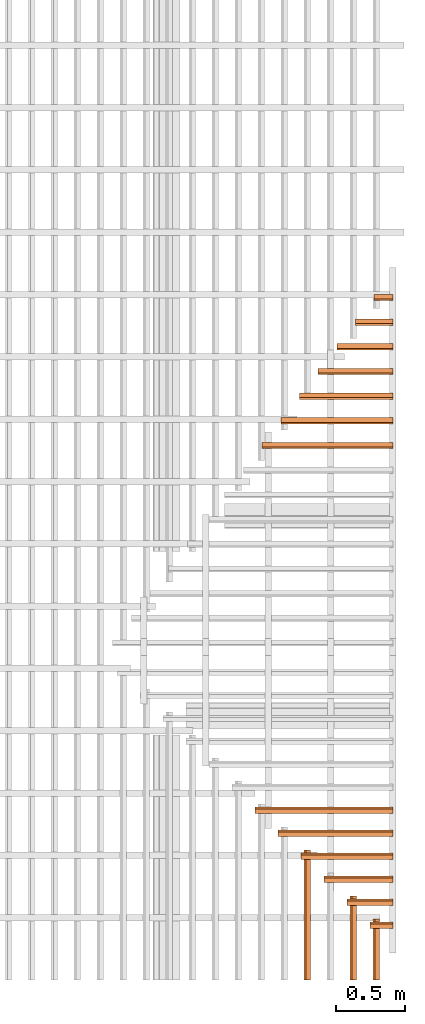
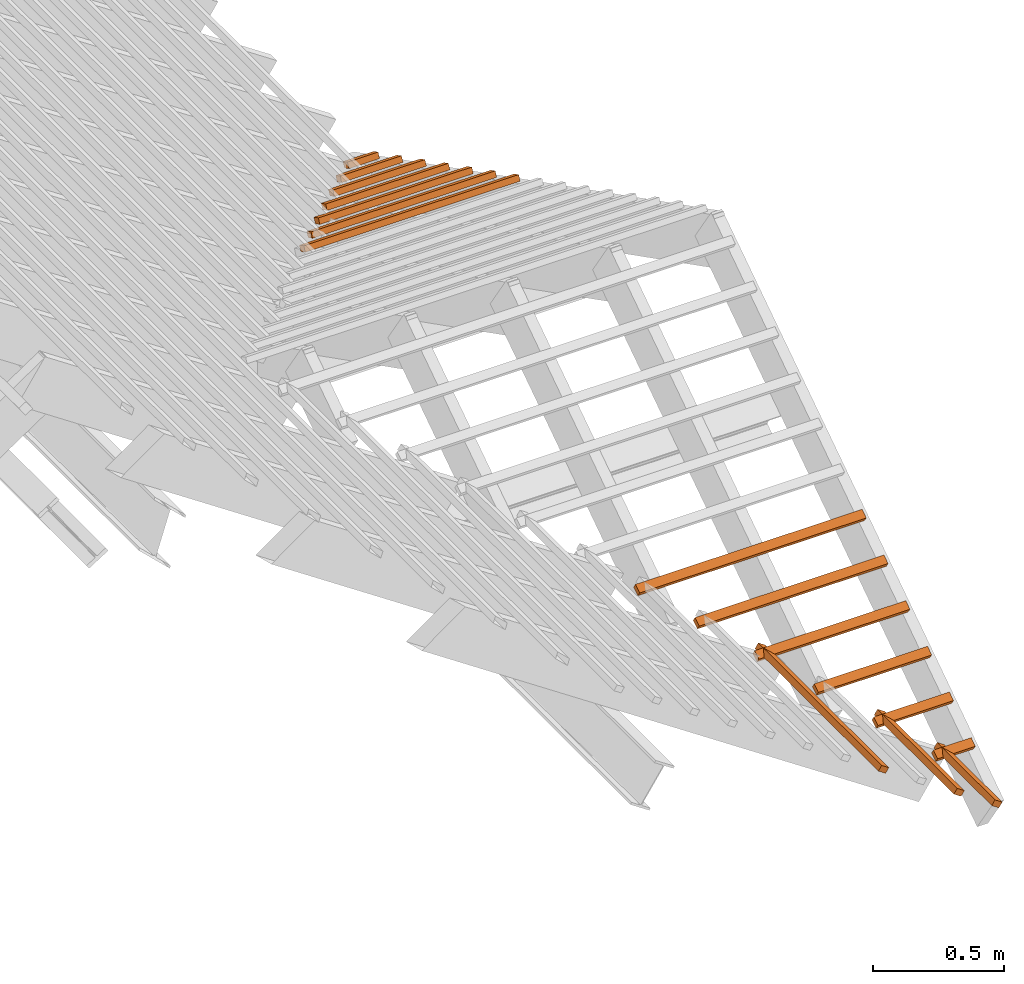
# One storey, part 3 of 3: 16 proxies, 4 elements without a shape of their own.
"""IFC4 building model written with IfcOpenShell, lengths in metres."""

from ifc_helpers import new_model, entity, si_unit, converted_unit, frame, frame_2d, origin_with_axes, origin_2d_with_axis, place, context, subcontext, project, library, spatial, rectangle, extrude, material, material_profile, profile_set, profile_usage, type_object, element, aggregate, save


model = new_model("IFC4")

# Units and contexts
model_context = context("Model", 3, precision=1e-05, world=origin_with_axes())
plan_context = context("Plan", 2, precision=1e-05, world=origin_2d_with_axis())
body_context = subcontext(model_context, "Body", "Model", "MODEL_VIEW")
ifc_project = project(units=[si_unit("LENGTHUNIT", "METRE"), converted_unit("PLANEANGLEUNIT", "degree", entity("IfcReal", 0.0174532925199433), si_unit("PLANEANGLEUNIT", "RADIAN"), dimensions=[0, 0, 0, 0, 0, 0, 0]), si_unit("AREAUNIT", "SQUARE_METRE"), si_unit("VOLUMEUNIT", "CUBIC_METRE")], contexts=[model_context, plan_context])
project_library_1 = library(declared=ifc_project)
project_library_2 = library(declared=ifc_project)
project_library_3 = library(declared=ifc_project)

# Site, building, storey
site_placement = place(None, frame((-0.0250487327575684, 0.0, 0.0), z_axis=(0.0, 0.0, 1.0), x_axis=(1.0, 0.0, 0.0)))
site = spatial("IfcSite", under=ifc_project, at=site_placement)
building_placement = place(site_placement, origin_with_axes())
building = spatial("IfcBuilding", under=site, at=building_placement, Name="Building")
storey_placement = place(building_placement, frame((0.0250487327575684, 0.0, 0.0), z_axis=(0.0, 0.0, 1.0), x_axis=(1.0, 0.0, 0.0)))
storey = spatial("IfcBuildingStorey", under=building, at=storey_placement, Name="Roof framing", CompositionType="ELEMENT", Elevation=0.0)

# Assemblies, proxies
assembly_1_placement = place(storey_placement, origin_with_axes())
assembly_1 = element("IfcElementAssembly", 1, at=assembly_1_placement, inside=storey, Name="battens")
assembly_2_placement = place(assembly_1_placement, frame((1.27500009536743, -6.61744490042422e-24, 2.40000009536743), z_axis=(0.557621447781006, -6.78052809385821e-09, 0.830095368602075), x_axis=(1.21597333116231e-08, 1.0, -6.86638795477696e-25)))
assembly_2 = element("IfcElementAssembly", 2, at=assembly_2_placement, Name="battens")
ifc_material = material(Name="Timber")
ifc_material_profile = material_profile(ifc_material, rectangle(XDim=0.038, YDim=0.026, at=frame_2d((0.0, 0.083), x_axis=(1.0, 0.0))))
ifc_profile_set = profile_set([ifc_material_profile])
ifc_profile_usage_1 = profile_usage(ifc_profile_set)
building_element_proxy_type = type_object("IfcBuildingElementProxyType", Name="batten", PredefinedType="NOTDEFINED", material=ifc_profile_set)
proxy_1_placement = place(assembly_2_placement, frame((0.441019033613307, 0.2, 0.0), z_axis=(-1.0, 0.0, 0.0), x_axis=(0.0, -1.0, 0.0)))
proxy_1 = element("IfcBuildingElementProxy", 3, at=proxy_1_placement, type_object=building_element_proxy_type, material=ifc_profile_usage_1, Name="batten", context=body_context, shape_type="SweptSolid", body=[
    extrude(rectangle(XDim=0.038, YDim=0.026, at=frame_2d((0.0, 0.083), x_axis=(1.0, 0.0))), origin_with_axes(), (0.0, 0.0, 1.0), 0.441019073436429),
])
ifc_profile_usage_2 = profile_usage(ifc_profile_set)
proxy_2_placement = place(assembly_2_placement, frame((0.607038093372632, 0.4, 0.0), z_axis=(-1.0, 0.0, 0.0), x_axis=(0.0, -1.0, 0.0)))
proxy_2 = element("IfcBuildingElementProxy", 4, at=proxy_2_placement, type_object=building_element_proxy_type, material=ifc_profile_usage_2, Name="batten", context=body_context, shape_type="SweptSolid", body=[
    extrude(rectangle(XDim=0.038, YDim=0.026, at=frame_2d((0.0, 0.083), x_axis=(1.0, 0.0))), origin_with_axes(), (0.0, 0.0, 1.0), 0.607038133195754),
])
ifc_profile_usage_3 = profile_usage(ifc_profile_set)
proxy_3_placement = place(assembly_2_placement, frame((0.939076212891283, 0.8, 0.0), z_axis=(-1.0, 1.18225013295358e-16, 0.0), x_axis=(-1.18225013295358e-16, -1.0, 0.0)))
proxy_3 = element("IfcBuildingElementProxy", 5, at=proxy_3_placement, type_object=building_element_proxy_type, material=ifc_profile_usage_3, Name="batten", context=body_context, shape_type="SweptSolid", body=[
    extrude(rectangle(XDim=0.038, YDim=0.026, at=frame_2d((0.0, 0.083), x_axis=(1.0, 0.0))), origin_with_axes(), (0.0, 0.0, 1.0), 0.939076252714405),
])
aggregate(assembly_2, [proxy_1, proxy_2, proxy_3])
assembly_3_placement = place(assembly_1_placement, frame((1.27500009536743, 5.06999969482422, 2.40000009536743), z_axis=(-1.8134071260532e-16, 0.453056810096847, 0.891481646936643), x_axis=(-1.0, -4.00260427751998e-16, -2.19767193434487e-32)))
assembly_3 = element("IfcElementAssembly", 6, at=assembly_3_placement, Name="battens")
ifc_profile_usage_4 = profile_usage(ifc_profile_set)
proxy_4_placement = place(assembly_3_placement, frame((0.134887384209834, 0.2, 0.0), z_axis=(-1.0, 6.17304736049078e-16, 0.0), x_axis=(-6.17304736049078e-16, -1.0, 0.0)))
proxy_4 = element("IfcBuildingElementProxy", 7, at=proxy_4_placement, type_object=building_element_proxy_type, material=ifc_profile_usage_4, Name="batten", context=body_context, shape_type="SweptSolid", body=[
    extrude(rectangle(XDim=0.038, YDim=0.026, at=frame_2d((0.0, 0.083), x_axis=(1.0, 0.0))), origin_with_axes(), (0.0, 0.0, 1.0), 0.134887555504299),
])
ifc_profile_usage_5 = profile_usage(ifc_profile_set)
proxy_5_placement = place(assembly_3_placement, frame((0.269774768419667, 0.4, 0.0), z_axis=(-1.0, 6.17304736049078e-16, 0.0), x_axis=(-6.17304736049078e-16, -1.0, 0.0)))
proxy_5 = element("IfcBuildingElementProxy", 8, at=proxy_5_placement, type_object=building_element_proxy_type, material=ifc_profile_usage_5, Name="batten", context=body_context, shape_type="SweptSolid", body=[
    extrude(rectangle(XDim=0.038, YDim=0.026, at=frame_2d((0.0, 0.083), x_axis=(1.0, 0.0))), origin_with_axes(), (0.0, 0.0, 1.0), 0.269775111008598),
])
ifc_profile_usage_6 = profile_usage(ifc_profile_set)
proxy_6_placement = place(assembly_3_placement, frame((0.404662152629501, 0.6, 0.0), z_axis=(-1.0, 5.48715320932513e-16, 0.0), x_axis=(-5.48715320932513e-16, -1.0, 0.0)))
proxy_6 = element("IfcBuildingElementProxy", 9, at=proxy_6_placement, type_object=building_element_proxy_type, material=ifc_profile_usage_6, Name="batten", context=body_context, shape_type="SweptSolid", body=[
    extrude(rectangle(XDim=0.038, YDim=0.026, at=frame_2d((0.0, 0.083), x_axis=(1.0, 0.0))), origin_with_axes(), (0.0, 0.0, 1.0), 0.404662666512898),
])
ifc_profile_usage_7 = profile_usage(ifc_profile_set)
proxy_7_placement = place(assembly_3_placement, frame((0.539549536839334, 0.8, 0.0), z_axis=(-1.0, -2.05768245349693e-16, 0.0), x_axis=(2.05768245349693e-16, -1.0, 0.0)))
proxy_7 = element("IfcBuildingElementProxy", 10, at=proxy_7_placement, type_object=building_element_proxy_type, material=ifc_profile_usage_7, Name="batten", context=body_context, shape_type="SweptSolid", body=[
    extrude(rectangle(XDim=0.038, YDim=0.026, at=frame_2d((0.0, 0.083), x_axis=(1.0, 0.0))), origin_with_axes(), (0.0, 0.0, 1.0), 0.539550222017197),
])
ifc_profile_usage_8 = profile_usage(ifc_profile_set)
proxy_8_placement = place(assembly_3_placement, frame((0.674436921049168, 1.0, 0.0), z_axis=(-1.0, 0.0, 0.0), x_axis=(0.0, -1.0, 0.0)))
proxy_8 = element("IfcBuildingElementProxy", 11, at=proxy_8_placement, type_object=building_element_proxy_type, material=ifc_profile_usage_8, Name="batten", context=body_context, shape_type="SweptSolid", body=[
    extrude(rectangle(XDim=0.038, YDim=0.026, at=frame_2d((0.0, 0.083), x_axis=(1.0, 0.0))), origin_with_axes(), (0.0, 0.0, 1.0), 0.674437777521496),
])
ifc_profile_usage_9 = profile_usage(ifc_profile_set)
proxy_9_placement = place(assembly_3_placement, frame((0.809324305259002, 1.2, 0.0), z_axis=(-1.0, 0.0, 0.0), x_axis=(0.0, -1.0, 0.0)))
proxy_9 = element("IfcBuildingElementProxy", 12, at=proxy_9_placement, type_object=building_element_proxy_type, material=ifc_profile_usage_9, Name="batten", context=body_context, shape_type="SweptSolid", body=[
    extrude(rectangle(XDim=0.038, YDim=0.026, at=frame_2d((0.0, 0.083), x_axis=(1.0, 0.0))), origin_with_axes(), (0.0, 0.0, 1.0), 0.809325333025795),
])
ifc_profile_usage_10 = profile_usage(ifc_profile_set)
proxy_10_placement = place(assembly_3_placement, frame((0.944211689468835, 1.4, 0.0), z_axis=(-1.0, 0.0, 0.0), x_axis=(0.0, -1.0, 0.0)))
proxy_10 = element("IfcBuildingElementProxy", 13, at=proxy_10_placement, type_object=building_element_proxy_type, material=ifc_profile_usage_10, Name="batten", context=body_context, shape_type="SweptSolid", body=[
    extrude(rectangle(XDim=0.038, YDim=0.026, at=frame_2d((0.0, 0.083), x_axis=(1.0, 0.0))), origin_with_axes(), (0.0, 0.0, 1.0), 0.944212888530094),
])
aggregate(assembly_3, [proxy_4, proxy_5, proxy_6, proxy_7, proxy_8, proxy_9, proxy_10])
assembly_4_placement = place(assembly_1_placement, frame((1.27500009536743, 0.274999976158142, 2.40000009536743), z_axis=(-5.93234342970621e-17, -0.55762137886684, 0.830095414895567), x_axis=(1.0, -1.0638658513706e-16, 0.0)))
assembly_4 = element("IfcElementAssembly", 14, at=assembly_4_placement, Name="battens")
aggregate(assembly_1, [assembly_2, assembly_3, assembly_4])
ifc_profile_usage_11 = profile_usage(ifc_profile_set)
proxy_11_placement = place(assembly_4_placement, frame((1.2649732309411e-06, 1.2, 0.0), z_axis=(-1.0, 4.45820806688113e-16, 0.0), x_axis=(-4.45820806688113e-16, -1.0, 0.0)))
proxy_11 = element("IfcBuildingElementProxy", 15, at=proxy_11_placement, type_object=building_element_proxy_type, material=ifc_profile_usage_11, Name="batten", context=body_context, shape_type="SweptSolid", body=[
    extrude(rectangle(XDim=0.038, YDim=0.026, at=frame_2d((0.0, 0.083), x_axis=(1.0, 0.0))), origin_with_axes(), (0.0, 0.0, 1.0), 0.996115935344262),
])
ifc_profile_usage_12 = profile_usage(ifc_profile_set)
proxy_12_placement = place(assembly_4_placement, frame((1.05414435891404e-06, 1.0, 0.0), z_axis=(-1.0, 0.0, 0.0), x_axis=(0.0, -1.0, 0.0)))
proxy_12 = element("IfcBuildingElementProxy", 16, at=proxy_12_placement, type_object=building_element_proxy_type, material=ifc_profile_usage_12, Name="batten", context=body_context, shape_type="SweptSolid", body=[
    extrude(rectangle(XDim=0.038, YDim=0.026, at=frame_2d((0.0, 0.083), x_axis=(1.0, 0.0))), origin_with_axes(), (0.0, 0.0, 1.0), 0.830096612786885),
])
ifc_profile_usage_13 = profile_usage(ifc_profile_set)
proxy_13_placement = place(assembly_4_placement, frame((8.43315487220053e-07, 0.8, 0.0), z_axis=(-1.0, 3.34365605016084e-16, 0.0), x_axis=(-3.34365605016084e-16, -1.0, 0.0)))
proxy_13 = element("IfcBuildingElementProxy", 17, at=proxy_13_placement, type_object=building_element_proxy_type, material=ifc_profile_usage_13, Name="batten", context=body_context, shape_type="SweptSolid", body=[
    extrude(rectangle(XDim=0.038, YDim=0.026, at=frame_2d((0.0, 0.083), x_axis=(1.0, 0.0))), origin_with_axes(), (0.0, 0.0, 1.0), 0.664077290229508),
])
ifc_profile_usage_14 = profile_usage(ifc_profile_set)
proxy_14_placement = place(assembly_4_placement, frame((6.32486615470551e-07, 0.6, 0.0), z_axis=(-1.0, 6.68731210032168e-16, 0.0), x_axis=(-6.68731210032168e-16, -1.0, 0.0)))
proxy_14 = element("IfcBuildingElementProxy", 18, at=proxy_14_placement, type_object=building_element_proxy_type, material=ifc_profile_usage_14, Name="batten", context=body_context, shape_type="SweptSolid", body=[
    extrude(rectangle(XDim=0.038, YDim=0.026, at=frame_2d((0.0, 0.083), x_axis=(1.0, 0.0))), origin_with_axes(), (0.0, 0.0, 1.0), 0.498057967672131),
])
ifc_profile_usage_15 = profile_usage(ifc_profile_set)
proxy_15_placement = place(assembly_4_placement, frame((4.21657743721049e-07, 0.4, 0.0), z_axis=(-1.0, 5.01548407524126e-16, 0.0), x_axis=(-5.01548407524126e-16, -1.0, 0.0)))
proxy_15 = element("IfcBuildingElementProxy", 19, at=proxy_15_placement, type_object=building_element_proxy_type, material=ifc_profile_usage_15, Name="batten", context=body_context, shape_type="SweptSolid", body=[
    extrude(rectangle(XDim=0.038, YDim=0.026, at=frame_2d((0.0, 0.083), x_axis=(1.0, 0.0))), origin_with_axes(), (0.0, 0.0, 1.0), 0.332038645114754),
])
ifc_profile_usage_16 = profile_usage(ifc_profile_set)
proxy_16_placement = place(assembly_4_placement, frame((2.10828871971547e-07, 0.2, 0.0), z_axis=(-1.0, 1.83901082758846e-15, 0.0), x_axis=(-1.83901082758846e-15, -1.0, 0.0)))
proxy_16 = element("IfcBuildingElementProxy", 20, at=proxy_16_placement, type_object=building_element_proxy_type, material=ifc_profile_usage_16, Name="batten", context=body_context, shape_type="SweptSolid", body=[
    extrude(rectangle(XDim=0.038, YDim=0.026, at=frame_2d((0.0, 0.083), x_axis=(1.0, 0.0))), origin_with_axes(), (0.0, 0.0, 1.0), 0.166019322557377),
])
aggregate(assembly_4, [proxy_11, proxy_12, proxy_13, proxy_14, proxy_15, proxy_16])

save(model, "model.ifc")
